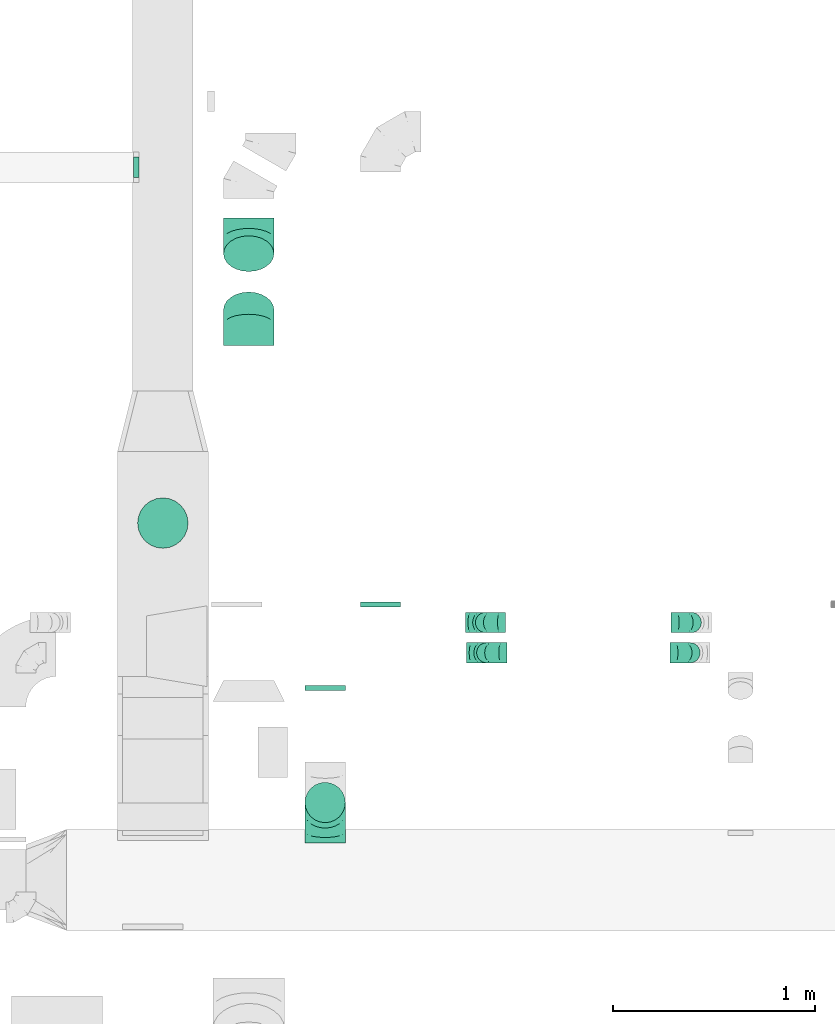
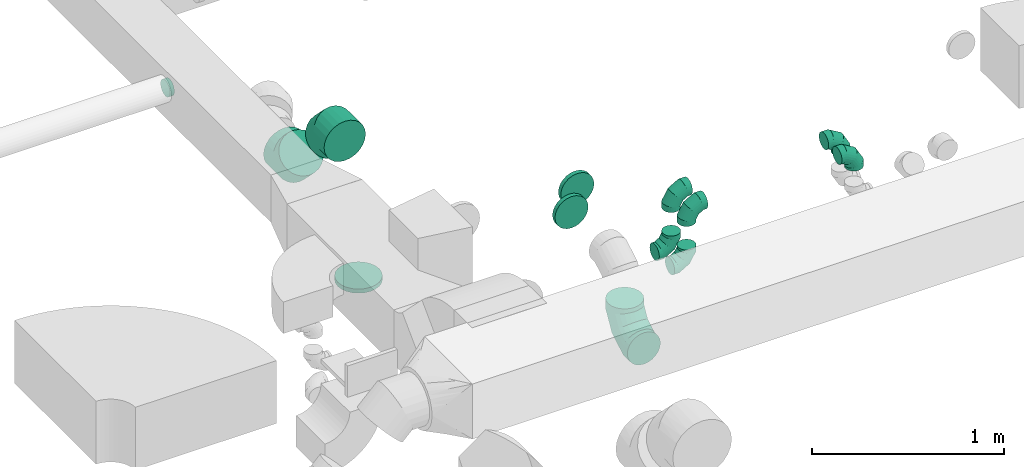
# One storey, part 30 of 62: 13 flow fittings.
"""IFC2X3 building model written with IfcOpenShell, lengths in millimetres."""

from ifc_helpers import new_model, entity, si_unit, converted_unit, derived_unit, direction, frame, origin, place, context, subcontext, project, spatial, faceted_brep, source, transform, mapped, material, type_object, type_shapes, element, save


model = new_model("IFC2X3")

# Units and contexts
model_context = context("Model", 3, precision=0.01, world=origin(), true_north=direction((6.12303176911189e-17, 1.0)))
body_context = subcontext(model_context, "Body", "Model", "MODEL_VIEW")
ifc_project = project(units=[si_unit("LENGTHUNIT", "METRE", prefix="MILLI"), si_unit("AREAUNIT", "SQUARE_METRE"), si_unit("VOLUMEUNIT", "CUBIC_METRE"), converted_unit("PLANEANGLEUNIT", "DEGREE", entity("IfcRatioMeasure", 0.0174532925199433), si_unit("PLANEANGLEUNIT", "RADIAN"), dimensions=[0, 0, 0, 0, 0, 0, 0]), si_unit("MASSUNIT", "GRAM", prefix="KILO"), derived_unit("MASSDENSITYUNIT", [(si_unit("MASSUNIT", "GRAM", prefix="KILO"), 1), (si_unit("LENGTHUNIT", "METRE"), -3)]), derived_unit("MOMENTOFINERTIAUNIT", [(si_unit("LENGTHUNIT", "METRE"), 4)]), si_unit("TIMEUNIT", "SECOND"), si_unit("FREQUENCYUNIT", "HERTZ"), si_unit("THERMODYNAMICTEMPERATUREUNIT", "DEGREE_CELSIUS"), derived_unit("THERMALTRANSMITTANCEUNIT", [(si_unit("MASSUNIT", "GRAM", prefix="KILO"), 1), (si_unit("THERMODYNAMICTEMPERATUREUNIT", "KELVIN"), -1), (si_unit("TIMEUNIT", "SECOND"), -3)]), derived_unit("VOLUMETRICFLOWRATEUNIT", [(si_unit("LENGTHUNIT", "METRE"), 3), (si_unit("TIMEUNIT", "SECOND"), -1)]), derived_unit("MASSFLOWRATEUNIT", [(si_unit("MASSUNIT", "GRAM", prefix="KILO"), 1), (si_unit("TIMEUNIT", "SECOND"), -1)]), derived_unit("ROTATIONALFREQUENCYUNIT", [(si_unit("TIMEUNIT", "SECOND"), -1)]), si_unit("ELECTRICCURRENTUNIT", "AMPERE"), si_unit("ELECTRICVOLTAGEUNIT", "VOLT"), si_unit("POWERUNIT", "WATT"), si_unit("FORCEUNIT", "NEWTON", prefix="KILO"), si_unit("ILLUMINANCEUNIT", "LUX"), si_unit("LUMINOUSFLUXUNIT", "LUMEN"), si_unit("LUMINOUSINTENSITYUNIT", "CANDELA"), derived_unit("USERDEFINED", [(si_unit("MASSUNIT", "GRAM", prefix="KILO"), -1), (si_unit("LENGTHUNIT", "METRE"), -2), (si_unit("TIMEUNIT", "SECOND"), 3), (si_unit("LUMINOUSFLUXUNIT", "LUMEN"), 1)]), derived_unit("LINEARVELOCITYUNIT", [(si_unit("LENGTHUNIT", "METRE"), 1), (si_unit("TIMEUNIT", "SECOND"), -1)]), si_unit("PRESSUREUNIT", "PASCAL"), derived_unit("USERDEFINED", [(si_unit("LENGTHUNIT", "METRE"), -2), (si_unit("MASSUNIT", "GRAM", prefix="KILO"), 1), (si_unit("TIMEUNIT", "SECOND"), -2)]), derived_unit("LINEARFORCEUNIT", [(si_unit("MASSUNIT", "GRAM", prefix="KILO"), 1), (si_unit("LENGTHUNIT", "METRE"), 1), (si_unit("TIMEUNIT", "SECOND"), -2), (si_unit("LENGTHUNIT", "METRE"), -1)]), derived_unit("PLANARFORCEUNIT", [(si_unit("MASSUNIT", "GRAM", prefix="KILO"), 1), (si_unit("LENGTHUNIT", "METRE"), 1), (si_unit("TIMEUNIT", "SECOND"), -2), (si_unit("LENGTHUNIT", "METRE"), -2)])], contexts=[model_context])

# Site, building, storey
site_placement = place(None, origin())
site = spatial("IfcSite", under=ifc_project, at=site_placement, CompositionType="ELEMENT")
building_placement = place(site_placement, origin())
building = spatial("IfcBuilding", under=site, at=building_placement, CompositionType="ELEMENT")
storey_placement = place(building_placement, frame((0.0, 0.0, 24000.0)))
storey = spatial("IfcBuildingStorey", under=building, at=storey_placement, CompositionType="ELEMENT", Elevation=24000.0)

# Flow fittings
ifc_material = material()
duct_fitting_type_1 = type_object("IfcDuctFittingType", PredefinedType="NOTDEFINED", material=ifc_material)
shared_shape_1 = source(origin(), body_context, "Body", "Brep", [
    faceted_brep([(-100.0, 0.0, -50.0), (-100.0, -12.94, -48.3), (-100.0, -25.0, -43.3), (-100.0, -35.36, -35.36), (-100.0, -43.3, -25.0), (-100.0, -48.3, -12.94), (-100.0, -50.0, 0.0), (-100.0, -48.3, 12.94), (-100.0, -43.3, 25.0), (-100.0, -35.36, 35.36), (-100.0, -25.0, 43.3), (-100.0, -12.94, 48.3), (-100.0, 0.0, 50.0), (-100.0, 12.94, 48.3), (-100.0, 25.0, 43.3), (-100.0, 35.36, 35.36), (-100.0, 43.3, 25.0), (-100.0, 48.3, 12.94), (-100.0, 50.0, 0.0), (-100.0, 48.3, -12.94), (-100.0, 43.3, -25.0), (-100.0, 35.36, -35.36), (-100.0, 25.0, -43.3), (-100.0, 12.94, -48.3), (-76.67, 12.94, 48.3), (-79.9, 25.0, 43.3), (-73.21, 0.0, 50.0), (-82.68, 35.36, 35.36), (-86.15, 48.3, 12.94), (-86.6, 50.0, 0.0), (-84.81, 43.3, 25.0), (-84.81, 43.3, -25.0), (-82.68, 35.36, -35.36), (-86.15, 48.3, -12.94), (-76.67, 12.94, -48.3), (-73.21, 0.0, -50.0), (-79.9, 25.0, -43.3), (-69.74, -12.94, -48.3), (-66.51, -25.0, -43.3), (-63.73, -35.36, -35.36), (-61.6, -43.3, -25.0), (-60.26, -48.3, -12.94), (-59.81, -50.0, 0.0), (-60.26, -48.3, 12.94), (-61.6, -43.3, 25.0), (-63.73, -35.36, 35.36), (-66.51, -25.0, 43.3), (-69.74, -12.94, 48.3), (-36.27, 36.27, 48.3), (-45.1, 45.1, 43.3), (-26.79, 26.79, 50.0), (-52.68, 52.68, 35.36), (-58.49, 58.49, 25.0), (-62.15, 62.15, 12.94), (-63.4, 63.4, 0.0), (-62.15, 62.15, -12.94), (-58.49, 58.49, -25.0), (-52.68, 52.68, -35.36), (-36.27, 36.27, -48.3), (-26.79, 26.79, -50.0), (-45.1, 45.1, -43.3), (-17.32, 17.32, -48.3), (-8.49, 8.49, -43.3), (-0.91, 0.91, -35.36), (4.9, -4.9, -25.0), (8.56, -8.56, -12.94), (9.81, -9.81, 0.0), (8.56, -8.56, 12.94), (4.9, -4.9, 25.0), (-0.91, 0.91, 35.36), (-8.49, 8.49, 43.3), (-17.32, 17.32, 48.3), (-12.94, 76.67, 48.3), (-25.0, 79.9, 43.3), (0.0, 73.21, 50.0), (-35.36, 82.68, 35.36), (-43.3, 84.81, 25.0), (-48.3, 86.15, 12.94), (-50.0, 86.6, 0.0), (-48.3, 86.15, -12.94), (-43.3, 84.81, -25.0), (-35.36, 82.68, -35.36), (-12.94, 76.67, -48.3), (0.0, 73.21, -50.0), (-25.0, 79.9, -43.3), (12.94, 69.74, -48.3), (25.0, 66.51, -43.3), (35.36, 63.73, -35.36), (43.3, 61.6, -25.0), (48.3, 60.26, -12.94), (50.0, 59.81, 0.0), (48.3, 60.26, 12.94), (43.3, 61.6, 25.0), (35.36, 63.73, 35.36), (25.0, 66.51, 43.3), (12.94, 69.74, 48.3), (-12.94, 100.0, -48.3), (-25.0, 100.0, -43.3), (-35.36, 100.0, -35.36), (-43.3, 100.0, -25.0), (-48.3, 100.0, -12.94), (-50.0, 100.0, 0.0), (-48.3, 100.0, 12.94), (-43.3, 100.0, 25.0), (-35.36, 100.0, 35.36), (-25.0, 100.0, 43.3), (-12.94, 100.0, 48.3), (0.0, 100.0, 50.0), (12.94, 100.0, 48.3), (25.0, 100.0, 43.3), (35.36, 100.0, 35.36), (43.3, 100.0, 25.0), (48.3, 100.0, 12.94), (50.0, 100.0, 0.0), (48.3, 100.0, -12.94), (43.3, 100.0, -25.0), (35.36, 100.0, -35.36), (25.0, 100.0, -43.3), (12.94, 100.0, -48.3), (0.0, 100.0, -50.0)], [[[0, 1, 2, 3, 4, 5, 6, 7, 8, 9, 10, 11, 12, 13, 14, 15, 16, 17, 18, 19, 20, 21, 22, 23]], [[24, 25, 14, 13]], [[26, 24, 13, 12]], [[14, 25, 27, 15]], [[28, 29, 18, 17]], [[30, 28, 17, 16]], [[15, 27, 30, 16]], [[20, 31, 32, 21]], [[33, 31, 20, 19]], [[18, 29, 33, 19]], [[34, 35, 0, 23]], [[36, 34, 23, 22]], [[32, 36, 22, 21]], [[2, 1, 37, 38]], [[3, 2, 38, 39]], [[0, 35, 37, 1]], [[5, 4, 40, 41]], [[6, 5, 41, 42]], [[3, 39, 40, 4]], [[6, 42, 43, 7]], [[7, 43, 44, 8]], [[8, 44, 45, 9]], [[10, 46, 47, 11]], [[11, 47, 26, 12]], [[10, 9, 45, 46]], [[48, 49, 25, 24]], [[50, 48, 24, 26]], [[27, 25, 49, 51]], [[52, 53, 28, 30]], [[51, 52, 30, 27]], [[29, 28, 53, 54]], [[55, 56, 31, 33]], [[54, 55, 33, 29]], [[57, 32, 31, 56]], [[58, 59, 35, 34]], [[60, 58, 34, 36]], [[57, 60, 36, 32]], [[37, 35, 59, 61]], [[38, 37, 61, 62]], [[39, 38, 62, 63]], [[41, 40, 64, 65]], [[42, 41, 65, 66]], [[63, 64, 40, 39]], [[43, 42, 66, 67]], [[44, 43, 67, 68]], [[68, 69, 45, 44]], [[46, 45, 69, 70]], [[47, 46, 70, 71]], [[26, 47, 71, 50]], [[72, 73, 49, 48]], [[74, 72, 48, 50]], [[51, 49, 73, 75]], [[76, 77, 53, 52]], [[75, 76, 52, 51]], [[54, 53, 77, 78]], [[79, 80, 56, 55]], [[78, 79, 55, 54]], [[81, 57, 56, 80]], [[82, 83, 59, 58]], [[84, 82, 58, 60]], [[81, 84, 60, 57]], [[61, 59, 83, 85]], [[62, 61, 85, 86]], [[63, 62, 86, 87]], [[65, 64, 88, 89]], [[66, 65, 89, 90]], [[87, 88, 64, 63]], [[67, 66, 90, 91]], [[68, 67, 91, 92]], [[92, 93, 69, 68]], [[70, 69, 93, 94]], [[71, 70, 94, 95]], [[50, 71, 95, 74]], [[96, 97, 98, 99, 100, 101, 102, 103, 104, 105, 106, 107, 108, 109, 110, 111, 112, 113, 114, 115, 116, 117, 118, 119]], [[72, 74, 107, 106]], [[73, 72, 106, 105]], [[75, 73, 105, 104]], [[77, 76, 103, 102]], [[78, 77, 102, 101]], [[75, 104, 103, 76]], [[78, 101, 100, 79]], [[79, 100, 99, 80]], [[80, 99, 98, 81]], [[96, 119, 83, 82]], [[97, 96, 82, 84]], [[84, 81, 98, 97]], [[83, 119, 118, 85]], [[85, 118, 117, 86]], [[86, 117, 116, 87]], [[88, 115, 114, 89]], [[89, 114, 113, 90]], [[87, 116, 115, 88]], [[91, 90, 113, 112]], [[92, 91, 112, 111]], [[93, 92, 111, 110]], [[95, 94, 109, 108]], [[74, 95, 108, 107]], [[110, 109, 94, 93]]]),
])
type_shapes(duct_fitting_type_1, [shared_shape_1])
for number, where, z_axis, x_axis in (
    (1, (42712.73, 10199.94, 3300.0), (0.0, -1.0, 0.0), (0.0, 0.0, 1.0)),
    (2, (41693.23, 10199.94, 3300.0), (0.0, 1.0, 0.0), (0.0, 0.0, 1.0)),
    (3, (42706.67, 10049.93, 3300.0), (0.0, 1.0, 0.0), (1.0, 0.0, 0.0)),
    (4, (41699.27, 10049.93, 3300.0), (0.0, -1.0, 0.0), (-1.0, 0.0, 0.0)),
    (5, (41699.27, 10049.93, 2950.0), (0.0, 1.0, 0.0), (0.0, 0.0, -1.0)),
    (6, (41693.23, 10199.94, 2950.0), (0.0, 1.0, 0.0), (0.0, 0.0, -1.0)),
):
    element("IfcFlowFitting", number, at=place(storey_placement, frame(where, z_axis=z_axis, x_axis=x_axis)), inside=storey, type_object=duct_fitting_type_1, material=ifc_material, context=body_context, shape_type="MappedRepresentation", body=[
        mapped(shared_shape_1, transform((0.0, 0.0, 0.0), scale=1.0)),
    ])
duct_fitting_type_2 = type_object("IfcDuctFittingType", PredefinedType="NOTDEFINED", material=ifc_material)
shared_shape_2 = source(origin(), body_context, "Body", "Brep", [
    faceted_brep([(20.0, 32.35, -120.74), (20.0, 62.5, -108.25), (20.0, 88.39, -88.39), (20.0, 108.25, -62.5), (20.0, 120.74, -32.35), (20.0, 125.0, 0.0), (20.0, 120.74, 32.35), (20.0, 108.25, 62.5), (20.0, 88.39, 88.39), (20.0, 62.5, 108.25), (20.0, 32.35, 120.74), (20.0, 0.0, 125.0), (20.0, -32.35, 120.74), (20.0, -62.5, 108.25), (20.0, -88.39, 88.39), (20.0, -108.25, 62.5), (20.0, -120.74, 32.35), (20.0, -125.0, 0.0), (20.0, -120.74, -32.35), (20.0, -108.25, -62.5), (20.0, -88.39, -88.39), (20.0, -62.5, -108.25), (20.0, -32.35, -120.74), (20.0, 0.0, -125.0), (0.0, 0.0, 125.0), (0.0, 32.35, 120.74), (-6.1, 32.35, 120.74), (-6.1, 0.0, 125.0), (0.0, 62.5, 108.25), (-6.1, 62.5, 108.25), (0.0, 88.39, 88.39), (-6.1, 88.39, 88.39), (0.0, 108.25, 62.5), (0.0, 120.74, 32.35), (-6.1, 120.74, 32.35), (-6.1, 108.25, 62.5), (0.0, 125.0, 0.0), (-6.1, 125.0, 0.0), (0.0, 120.74, -32.35), (-6.1, 120.74, -32.35), (0.0, 108.25, -62.5), (-6.1, 108.25, -62.5), (0.0, 88.39, -88.39), (-6.1, 88.39, -88.39), (0.0, 62.5, -108.25), (0.0, 32.35, -120.74), (-6.1, 32.35, -120.74), (-6.1, 62.5, -108.25), (0.0, 0.0, -125.0), (-6.1, 0.0, -125.0), (0.0, -32.35, -120.74), (-6.1, -32.35, -120.74), (0.0, -62.5, -108.25), (-6.1, -62.5, -108.25), (0.0, -88.39, -88.39), (-6.1, -88.39, -88.39), (0.0, -108.25, -62.5), (0.0, -120.74, -32.35), (-6.1, -120.74, -32.35), (-6.1, -108.25, -62.5), (0.0, -125.0, 0.0), (-6.1, -125.0, 0.0), (0.0, -120.74, 32.35), (-6.1, -120.74, 32.35), (0.0, -108.25, 62.5), (-6.1, -108.25, 62.5), (0.0, -88.39, 88.39), (-6.1, -88.39, 88.39), (0.0, -62.5, 108.25), (0.0, -32.35, 120.74), (-6.1, -32.35, 120.74), (-6.1, -62.5, 108.25)], [[[0, 1, 2, 3, 4, 5, 6, 7, 8, 9, 10, 11, 12, 13, 14, 15, 16, 17, 18, 19, 20, 21, 22, 23]], [[24, 11, 10, 25, 26, 27]], [[25, 10, 9, 28, 29, 26]], [[28, 9, 8, 30, 31, 29]], [[32, 7, 6, 33, 34, 35]], [[33, 6, 5, 36, 37, 34]], [[30, 8, 7, 32, 35, 31]], [[36, 5, 4, 38, 39, 37]], [[38, 4, 3, 40, 41, 39]], [[40, 3, 2, 42, 43, 41]], [[44, 1, 0, 45, 46, 47]], [[45, 0, 23, 48, 49, 46]], [[42, 2, 1, 44, 47, 43]], [[48, 23, 22, 50, 51, 49]], [[50, 22, 21, 52, 53, 51]], [[52, 21, 20, 54, 55, 53]], [[56, 19, 18, 57, 58, 59]], [[57, 18, 17, 60, 61, 58]], [[54, 20, 19, 56, 59, 55]], [[60, 17, 16, 62, 63, 61]], [[62, 16, 15, 64, 65, 63]], [[64, 15, 14, 66, 67, 65]], [[68, 13, 12, 69, 70, 71]], [[69, 12, 11, 24, 27, 70]], [[66, 14, 13, 68, 71, 67]], [[49, 51, 53, 55, 59, 58, 61, 63, 65, 67, 71, 70, 27, 26, 29, 31, 35, 34, 37, 39, 41, 43, 47, 46]]]),
])
type_shapes(duct_fitting_type_2, [shared_shape_2])
flow_fitting_1_placement = place(storey_placement, frame((40095.11, 10692.43, 3020.0), z_axis=(0.0, -1.0, 0.0), x_axis=(0.0, 0.0, -1.0)))
element("IfcFlowFitting", 7, at=flow_fitting_1_placement, inside=storey, type_object=duct_fitting_type_2, material=ifc_material, context=body_context, shape_type="MappedRepresentation", body=[
    mapped(shared_shape_2, transform((0.0, 0.0, 0.0), scale=1.0)),
])
duct_fitting_type_3 = type_object("IfcDuctFittingType", PredefinedType="NOTDEFINED", material=ifc_material)
shared_shape_3 = source(origin(), body_context, "Body", "Brep", [
    faceted_brep([(-200.0, 0.0, -100.0), (-200.0, -25.88, -96.59), (-200.0, -50.0, -86.6), (-200.0, -70.71, -70.71), (-200.0, -86.6, -50.0), (-200.0, -96.59, -25.88), (-200.0, -100.0, 0.0), (-200.0, -96.59, 25.88), (-200.0, -86.6, 50.0), (-200.0, -70.71, 70.71), (-200.0, -50.0, 86.6), (-200.0, -25.88, 96.59), (-200.0, 0.0, 100.0), (-200.0, 25.88, 96.59), (-200.0, 50.0, 86.6), (-200.0, 70.71, 70.71), (-200.0, 86.6, 50.0), (-200.0, 96.59, 25.88), (-200.0, 100.0, 0.0), (-200.0, 96.59, -25.88), (-200.0, 86.6, -50.0), (-200.0, 70.71, -70.71), (-200.0, 50.0, -86.6), (-200.0, 25.88, -96.59), (-153.35, 25.88, 96.59), (-159.81, 50.0, 86.6), (-146.41, 0.0, 100.0), (-165.36, 70.71, 70.71), (-172.29, 96.59, 25.88), (-173.21, 100.0, 0.0), (-169.62, 86.6, 50.0), (-169.62, 86.6, -50.0), (-165.36, 70.71, -70.71), (-172.29, 96.59, -25.88), (-153.35, 25.88, -96.59), (-146.41, 0.0, -100.0), (-159.81, 50.0, -86.6), (-139.48, -25.88, -96.59), (-133.01, -50.0, -86.6), (-127.46, -70.71, -70.71), (-123.21, -86.6, -50.0), (-120.53, -96.59, -25.88), (-119.62, -100.0, 0.0), (-120.53, -96.59, 25.88), (-123.21, -86.6, 50.0), (-127.46, -70.71, 70.71), (-133.01, -50.0, 86.6), (-139.48, -25.88, 96.59), (-72.54, 72.54, 96.59), (-90.19, 90.19, 86.6), (-53.59, 53.59, 100.0), (-105.35, 105.35, 70.71), (-116.99, 116.99, 50.0), (-124.3, 124.3, 25.88), (-126.79, 126.79, 0.0), (-124.3, 124.3, -25.88), (-116.99, 116.99, -50.0), (-105.35, 105.35, -70.71), (-72.54, 72.54, -96.59), (-53.59, 53.59, -100.0), (-90.19, 90.19, -86.6), (-34.64, 34.64, -96.59), (-16.99, 16.99, -86.6), (-1.83, 1.83, -70.71), (9.81, -9.81, -50.0), (17.12, -17.12, -25.88), (19.62, -19.62, 0.0), (17.12, -17.12, 25.88), (9.81, -9.81, 50.0), (-1.83, 1.83, 70.71), (-16.99, 16.99, 86.6), (-34.64, 34.64, 96.59), (-25.88, 153.35, 96.59), (-50.0, 159.81, 86.6), (0.0, 146.41, 100.0), (-70.71, 165.36, 70.71), (-86.6, 169.62, 50.0), (-96.59, 172.29, 25.88), (-100.0, 173.21, 0.0), (-96.59, 172.29, -25.88), (-86.6, 169.62, -50.0), (-70.71, 165.36, -70.71), (-25.88, 153.35, -96.59), (0.0, 146.41, -100.0), (-50.0, 159.81, -86.6), (25.88, 139.48, -96.59), (50.0, 133.01, -86.6), (70.71, 127.46, -70.71), (86.6, 123.21, -50.0), (96.59, 120.53, -25.88), (100.0, 119.62, 0.0), (96.59, 120.53, 25.88), (86.6, 123.21, 50.0), (70.71, 127.46, 70.71), (50.0, 133.01, 86.6), (25.88, 139.48, 96.59), (-25.88, 200.0, -96.59), (-50.0, 200.0, -86.6), (-70.71, 200.0, -70.71), (-86.6, 200.0, -50.0), (-96.59, 200.0, -25.88), (-100.0, 200.0, 0.0), (-96.59, 200.0, 25.88), (-86.6, 200.0, 50.0), (-70.71, 200.0, 70.71), (-50.0, 200.0, 86.6), (-25.88, 200.0, 96.59), (0.0, 200.0, 100.0), (25.88, 200.0, 96.59), (50.0, 200.0, 86.6), (70.71, 200.0, 70.71), (86.6, 200.0, 50.0), (96.59, 200.0, 25.88), (100.0, 200.0, 0.0), (96.59, 200.0, -25.88), (86.6, 200.0, -50.0), (70.71, 200.0, -70.71), (50.0, 200.0, -86.6), (25.88, 200.0, -96.59), (0.0, 200.0, -100.0)], [[[0, 1, 2, 3, 4, 5, 6, 7, 8, 9, 10, 11, 12, 13, 14, 15, 16, 17, 18, 19, 20, 21, 22, 23]], [[24, 25, 14, 13]], [[26, 24, 13, 12]], [[14, 25, 27, 15]], [[28, 29, 18, 17]], [[30, 28, 17, 16]], [[15, 27, 30, 16]], [[20, 31, 32, 21]], [[33, 31, 20, 19]], [[18, 29, 33, 19]], [[34, 35, 0, 23]], [[36, 34, 23, 22]], [[32, 36, 22, 21]], [[1, 0, 35, 37]], [[2, 1, 37, 38]], [[38, 39, 3, 2]], [[5, 4, 40, 41]], [[6, 5, 41, 42]], [[39, 40, 4, 3]], [[6, 42, 43, 7]], [[7, 43, 44, 8]], [[8, 44, 45, 9]], [[9, 45, 46, 10]], [[10, 46, 47, 11]], [[26, 12, 11, 47]], [[48, 49, 25, 24]], [[50, 48, 24, 26]], [[27, 25, 49, 51]], [[52, 53, 28, 30]], [[51, 52, 30, 27]], [[29, 28, 53, 54]], [[55, 56, 31, 33]], [[54, 55, 33, 29]], [[32, 31, 56, 57]], [[58, 59, 35, 34]], [[60, 58, 34, 36]], [[57, 60, 36, 32]], [[37, 35, 59, 61]], [[38, 37, 61, 62]], [[39, 38, 62, 63]], [[41, 40, 64, 65]], [[42, 41, 65, 66]], [[63, 64, 40, 39]], [[43, 42, 66, 67]], [[44, 43, 67, 68]], [[68, 69, 45, 44]], [[46, 45, 69, 70]], [[47, 46, 70, 71]], [[26, 47, 71, 50]], [[72, 73, 49, 48]], [[74, 72, 48, 50]], [[51, 49, 73, 75]], [[76, 77, 53, 52]], [[75, 76, 52, 51]], [[54, 53, 77, 78]], [[79, 80, 56, 55]], [[78, 79, 55, 54]], [[57, 56, 80, 81]], [[82, 83, 59, 58]], [[84, 82, 58, 60]], [[81, 84, 60, 57]], [[61, 59, 83, 85]], [[62, 61, 85, 86]], [[63, 62, 86, 87]], [[65, 64, 88, 89]], [[66, 65, 89, 90]], [[87, 88, 64, 63]], [[67, 66, 90, 91]], [[68, 67, 91, 92]], [[92, 93, 69, 68]], [[70, 69, 93, 94]], [[71, 70, 94, 95]], [[50, 71, 95, 74]], [[96, 97, 98, 99, 100, 101, 102, 103, 104, 105, 106, 107, 108, 109, 110, 111, 112, 113, 114, 115, 116, 117, 118, 119]], [[72, 74, 107, 106]], [[73, 72, 106, 105]], [[75, 73, 105, 104]], [[102, 101, 78, 77]], [[103, 102, 77, 76]], [[75, 104, 103, 76]], [[78, 101, 100, 79]], [[79, 100, 99, 80]], [[80, 99, 98, 81]], [[84, 97, 96, 82]], [[82, 96, 119, 83]], [[84, 81, 98, 97]], [[118, 117, 86, 85]], [[119, 118, 85, 83]], [[116, 87, 86, 117]], [[88, 115, 114, 89]], [[89, 114, 113, 90]], [[115, 88, 87, 116]], [[91, 90, 113, 112]], [[92, 91, 112, 111]], [[111, 110, 93, 92]], [[95, 94, 109, 108]], [[74, 95, 108, 107]], [[110, 109, 94, 93]]]),
])
type_shapes(duct_fitting_type_3, [shared_shape_3])
flow_fitting_2_placement = place(storey_placement, frame((40899.04, 9308.41, 3240.0), z_axis=(-1.0, 0.0, 0.0), x_axis=(0.0, 0.0, -1.0)))
element("IfcFlowFitting", 8, at=flow_fitting_2_placement, inside=storey, type_object=duct_fitting_type_3, material=ifc_material, context=body_context, shape_type="MappedRepresentation", body=[
    mapped(shared_shape_3, transform((0.0, 0.0, 0.0), scale=1.0)),
])
duct_fitting_type_4 = type_object("IfcDuctFittingType", PredefinedType="NOTDEFINED", material=ifc_material)
shared_shape_4 = source(origin(), body_context, "Body", "Brep", [
    faceted_brep([(20.0, 25.88, -96.59), (20.0, 50.0, -86.6), (20.0, 70.71, -70.71), (20.0, 86.6, -50.0), (20.0, 96.59, -25.88), (20.0, 100.0, 0.0), (20.0, 96.59, 25.88), (20.0, 86.6, 50.0), (20.0, 70.71, 70.71), (20.0, 50.0, 86.6), (20.0, 25.88, 96.59), (20.0, 0.0, 100.0), (20.0, -25.88, 96.59), (20.0, -50.0, 86.6), (20.0, -70.71, 70.71), (20.0, -86.6, 50.0), (20.0, -96.59, 25.88), (20.0, -100.0, 0.0), (20.0, -96.59, -25.88), (20.0, -86.6, -50.0), (20.0, -70.71, -70.71), (20.0, -50.0, -86.6), (20.0, -25.88, -96.59), (20.0, 0.0, -100.0), (0.0, 0.0, 100.0), (0.0, 25.88, 96.59), (-6.1, 25.88, 96.59), (-6.1, 0.0, 100.0), (0.0, 50.0, 86.6), (-6.1, 50.0, 86.6), (0.0, 70.71, 70.71), (-6.1, 70.71, 70.71), (0.0, 86.6, 50.0), (0.0, 96.59, 25.88), (-6.1, 96.59, 25.88), (-6.1, 86.6, 50.0), (0.0, 100.0, 0.0), (-6.1, 100.0, 0.0), (0.0, 96.59, -25.88), (-6.1, 96.59, -25.88), (0.0, 86.6, -50.0), (-6.1, 86.6, -50.0), (0.0, 70.71, -70.71), (-6.1, 70.71, -70.71), (0.0, 50.0, -86.6), (0.0, 25.88, -96.59), (-6.1, 25.88, -96.59), (-6.1, 50.0, -86.6), (0.0, 0.0, -100.0), (-6.1, 0.0, -100.0), (0.0, -25.88, -96.59), (-6.1, -25.88, -96.59), (0.0, -50.0, -86.6), (-6.1, -50.0, -86.6), (0.0, -70.71, -70.71), (-6.1, -70.71, -70.71), (0.0, -86.6, -50.0), (0.0, -96.59, -25.88), (-6.1, -96.59, -25.88), (-6.1, -86.6, -50.0), (0.0, -100.0, 0.0), (-6.1, -100.0, 0.0), (0.0, -96.59, 25.88), (-6.1, -96.59, 25.88), (0.0, -86.6, 50.0), (-6.1, -86.6, 50.0), (0.0, -70.71, 70.71), (-6.1, -70.71, 70.71), (0.0, -50.0, 86.6), (0.0, -25.88, 96.59), (-6.1, -25.88, 96.59), (-6.1, -50.0, 86.6)], [[[0, 1, 2, 3, 4, 5, 6, 7, 8, 9, 10, 11, 12, 13, 14, 15, 16, 17, 18, 19, 20, 21, 22, 23]], [[24, 11, 10, 25, 26, 27]], [[25, 10, 9, 28, 29, 26]], [[28, 9, 8, 30, 31, 29]], [[32, 7, 6, 33, 34, 35]], [[33, 6, 5, 36, 37, 34]], [[30, 8, 7, 32, 35, 31]], [[36, 5, 4, 38, 39, 37]], [[38, 4, 3, 40, 41, 39]], [[40, 3, 2, 42, 43, 41]], [[44, 1, 0, 45, 46, 47]], [[45, 0, 23, 48, 49, 46]], [[42, 2, 1, 44, 47, 43]], [[48, 23, 22, 50, 51, 49]], [[50, 22, 21, 52, 53, 51]], [[52, 21, 20, 54, 55, 53]], [[56, 19, 18, 57, 58, 59]], [[57, 18, 17, 60, 61, 58]], [[54, 20, 19, 56, 59, 55]], [[60, 17, 16, 62, 63, 61]], [[62, 16, 15, 64, 65, 63]], [[64, 15, 14, 66, 67, 65]], [[68, 13, 12, 69, 70, 71]], [[69, 12, 11, 24, 27, 70]], [[66, 14, 13, 68, 71, 67]], [[49, 51, 53, 55, 59, 58, 61, 63, 65, 67, 71, 70, 27, 26, 29, 31, 35, 34, 37, 39, 41, 43, 47, 46]]]),
])
type_shapes(duct_fitting_type_4, [shared_shape_4])
flow_fitting_3_placement = place(storey_placement, frame((40899.04, 9882.41, 3650.0), z_axis=(0.0, 0.0, -1.0), x_axis=(0.0, -1.0, 0.0)))
element("IfcFlowFitting", 9, at=flow_fitting_3_placement, inside=storey, type_object=duct_fitting_type_4, material=ifc_material, context=body_context, shape_type="MappedRepresentation", body=[
    mapped(shared_shape_4, transform((0.0, 0.0, 0.0), scale=1.0)),
])
duct_fitting_type_5 = type_object("IfcDuctFittingType", PredefinedType="NOTDEFINED", material=ifc_material)
shared_shape_5 = source(origin(), body_context, "Body", "Brep", [
    faceted_brep([(20.0, 0.0, -50.0), (20.0, 12.94, -48.3), (20.0, 25.0, -43.3), (20.0, 35.36, -35.36), (20.0, 43.3, -25.0), (20.0, 48.3, -12.94), (20.0, 50.0, 0.0), (20.0, 48.3, 12.94), (20.0, 43.3, 25.0), (20.0, 35.36, 35.36), (20.0, 25.0, 43.3), (20.0, 12.94, 48.3), (20.0, 0.0, 50.0), (20.0, -12.94, 48.3), (20.0, -25.0, 43.3), (20.0, -35.36, 35.36), (20.0, -43.3, 25.0), (20.0, -48.3, 12.94), (20.0, -50.0, 0.0), (20.0, -48.3, -12.94), (20.0, -43.3, -25.0), (20.0, -35.36, -35.36), (20.0, -25.0, -43.3), (20.0, -12.94, -48.3), (0.0, 0.0, 50.0), (-6.1, 0.0, 50.0), (-6.1, -12.94, 48.3), (0.0, -12.94, 48.3), (-6.1, -25.0, 43.3), (0.0, -25.0, 43.3), (0.0, -35.36, 35.36), (-6.1, -35.36, 35.36), (0.0, -43.3, 25.0), (-6.1, -43.3, 25.0), (-6.1, -48.3, 12.94), (0.0, -48.3, 12.94), (-6.1, -50.0, 0.0), (0.0, -50.0, 0.0), (-6.1, -48.3, -12.94), (0.0, -48.3, -12.94), (-6.1, -43.3, -25.0), (0.0, -43.3, -25.0), (0.0, -35.36, -35.36), (-6.1, -35.36, -35.36), (0.0, -25.0, -43.3), (-6.1, -25.0, -43.3), (-6.1, -12.94, -48.3), (0.0, -12.94, -48.3), (-6.1, 0.0, -50.0), (0.0, 0.0, -50.0), (-6.1, 12.94, -48.3), (0.0, 12.94, -48.3), (-6.1, 25.0, -43.3), (0.0, 25.0, -43.3), (0.0, 35.36, -35.36), (-6.1, 35.36, -35.36), (0.0, 43.3, -25.0), (-6.1, 43.3, -25.0), (-6.1, 48.3, -12.94), (0.0, 48.3, -12.94), (-6.1, 50.0, 0.0), (0.0, 50.0, 0.0), (-6.1, 48.3, 12.94), (0.0, 48.3, 12.94), (-6.1, 43.3, 25.0), (0.0, 43.3, 25.0), (0.0, 35.36, 35.36), (-6.1, 35.36, 35.36), (0.0, 25.0, 43.3), (-6.1, 25.0, 43.3), (-6.1, 12.94, 48.3), (0.0, 12.94, 48.3)], [[[0, 1, 2, 3, 4, 5, 6, 7, 8, 9, 10, 11, 12, 13, 14, 15, 16, 17, 18, 19, 20, 21, 22, 23]], [[13, 12, 24, 25, 26, 27]], [[14, 13, 27, 26, 28, 29]], [[30, 15, 14, 29, 28, 31]], [[17, 16, 32, 33, 34, 35]], [[18, 17, 35, 34, 36, 37]], [[32, 16, 15, 30, 31, 33]], [[19, 18, 37, 36, 38, 39]], [[20, 19, 39, 38, 40, 41]], [[42, 21, 20, 41, 40, 43]], [[23, 22, 44, 45, 46, 47]], [[0, 23, 47, 46, 48, 49]], [[44, 22, 21, 42, 43, 45]], [[1, 0, 49, 48, 50, 51]], [[2, 1, 51, 50, 52, 53]], [[54, 3, 2, 53, 52, 55]], [[5, 4, 56, 57, 58, 59]], [[6, 5, 59, 58, 60, 61]], [[56, 4, 3, 54, 55, 57]], [[7, 6, 61, 60, 62, 63]], [[8, 7, 63, 62, 64, 65]], [[66, 9, 8, 65, 64, 67]], [[11, 10, 68, 69, 70, 71]], [[12, 11, 71, 70, 25, 24]], [[68, 10, 9, 66, 67, 69]], [[46, 45, 43, 40, 38, 36, 34, 33, 31, 28, 26, 25, 70, 69, 67, 64, 62, 60, 58, 57, 55, 52, 50, 48]]]),
])
type_shapes(duct_fitting_type_5, [shared_shape_5])
flow_fitting_4_placement = place(storey_placement, frame((39970.11, 12455.11, 3200.0), z_axis=(0.0, 0.0, -1.0), x_axis=(-1.0, 0.0, 0.0)))
element("IfcFlowFitting", 10, at=flow_fitting_4_placement, inside=storey, type_object=duct_fitting_type_5, material=ifc_material, context=body_context, shape_type="MappedRepresentation", body=[
    mapped(shared_shape_5, transform((0.0, 0.0, 0.0), scale=1.0)),
])
duct_fitting_type_6 = type_object("IfcDuctFittingType", PredefinedType="NOTDEFINED", material=ifc_material)
shared_shape_6 = source(origin(), body_context, "Body", "Brep", [
    faceted_brep([(20.0, 0.0, -100.0), (20.0, 25.88, -96.59), (20.0, 50.0, -86.6), (20.0, 70.71, -70.71), (20.0, 86.6, -50.0), (20.0, 96.59, -25.88), (20.0, 100.0, 0.0), (20.0, 96.59, 25.88), (20.0, 86.6, 50.0), (20.0, 70.71, 70.71), (20.0, 50.0, 86.6), (20.0, 25.88, 96.59), (20.0, 0.0, 100.0), (20.0, -25.88, 96.59), (20.0, -50.0, 86.6), (20.0, -70.71, 70.71), (20.0, -86.6, 50.0), (20.0, -96.59, 25.88), (20.0, -100.0, 0.0), (20.0, -96.59, -25.88), (20.0, -86.6, -50.0), (20.0, -70.71, -70.71), (20.0, -50.0, -86.6), (20.0, -25.88, -96.59), (0.0, 0.0, 100.0), (-6.1, 0.0, 100.0), (-6.1, -25.88, 96.59), (0.0, -25.88, 96.59), (-6.1, -50.0, 86.6), (0.0, -50.0, 86.6), (0.0, -70.71, 70.71), (-6.1, -70.71, 70.71), (0.0, -86.6, 50.0), (-6.1, -86.6, 50.0), (-6.1, -96.59, 25.88), (0.0, -96.59, 25.88), (-6.1, -100.0, 0.0), (0.0, -100.0, 0.0), (-6.1, -96.59, -25.88), (0.0, -96.59, -25.88), (-6.1, -86.6, -50.0), (0.0, -86.6, -50.0), (0.0, -70.71, -70.71), (-6.1, -70.71, -70.71), (0.0, -50.0, -86.6), (-6.1, -50.0, -86.6), (-6.1, -25.88, -96.59), (0.0, -25.88, -96.59), (-6.1, 0.0, -100.0), (0.0, 0.0, -100.0), (-6.1, 25.88, -96.59), (0.0, 25.88, -96.59), (-6.1, 50.0, -86.6), (0.0, 50.0, -86.6), (0.0, 70.71, -70.71), (-6.1, 70.71, -70.71), (0.0, 86.6, -50.0), (-6.1, 86.6, -50.0), (-6.1, 96.59, -25.88), (0.0, 96.59, -25.88), (-6.1, 100.0, 0.0), (0.0, 100.0, 0.0), (-6.1, 96.59, 25.88), (0.0, 96.59, 25.88), (-6.1, 86.6, 50.0), (0.0, 86.6, 50.0), (0.0, 70.71, 70.71), (-6.1, 70.71, 70.71), (0.0, 50.0, 86.6), (-6.1, 50.0, 86.6), (-6.1, 25.88, 96.59), (0.0, 25.88, 96.59)], [[[0, 1, 2, 3, 4, 5, 6, 7, 8, 9, 10, 11, 12, 13, 14, 15, 16, 17, 18, 19, 20, 21, 22, 23]], [[13, 12, 24, 25, 26, 27]], [[14, 13, 27, 26, 28, 29]], [[30, 15, 14, 29, 28, 31]], [[17, 16, 32, 33, 34, 35]], [[18, 17, 35, 34, 36, 37]], [[32, 16, 15, 30, 31, 33]], [[19, 18, 37, 36, 38, 39]], [[20, 19, 39, 38, 40, 41]], [[42, 21, 20, 41, 40, 43]], [[23, 22, 44, 45, 46, 47]], [[0, 23, 47, 46, 48, 49]], [[44, 22, 21, 42, 43, 45]], [[1, 0, 49, 48, 50, 51]], [[2, 1, 51, 50, 52, 53]], [[54, 3, 2, 53, 52, 55]], [[5, 4, 56, 57, 58, 59]], [[6, 5, 59, 58, 60, 61]], [[56, 4, 3, 54, 55, 57]], [[7, 6, 61, 60, 62, 63]], [[8, 7, 63, 62, 64, 65]], [[66, 9, 8, 65, 64, 67]], [[11, 10, 68, 69, 70, 71]], [[12, 11, 71, 70, 25, 24]], [[68, 10, 9, 66, 67, 69]], [[46, 45, 43, 40, 38, 36, 34, 33, 31, 28, 26, 25, 70, 69, 67, 64, 62, 60, 58, 57, 55, 52, 50, 48]]]),
])
type_shapes(duct_fitting_type_6, [shared_shape_6])
flow_fitting_5_placement = place(storey_placement, frame((41173.1, 10282.41, 3450.0), z_axis=(0.0, 0.0, -1.0), x_axis=(0.0, 1.0, 0.0)))
element("IfcFlowFitting", 11, at=flow_fitting_5_placement, inside=storey, type_object=duct_fitting_type_6, material=ifc_material, context=body_context, shape_type="MappedRepresentation", body=[
    mapped(shared_shape_6, transform((0.0, 0.0, 0.0), scale=1.0)),
])
duct_fitting_type_7 = type_object("IfcDuctFittingType", PredefinedType="NOTDEFINED", material=ifc_material)
shared_shape_7 = source(origin(), body_context, "Body", "Brep", [
    faceted_brep([(-103.55, 0.0, -125.0), (-103.55, -32.35, -120.74), (-103.55, -62.5, -108.25), (-103.55, -88.39, -88.39), (-103.55, -108.25, -62.5), (-103.55, -120.74, -32.35), (-103.55, -125.0, 0.0), (-103.55, -120.74, 32.35), (-103.55, -108.25, 62.5), (-103.55, -88.39, 88.39), (-103.55, -62.5, 108.25), (-103.55, -32.35, 120.74), (-103.55, 0.0, 125.0), (-103.55, 32.35, 120.74), (-103.55, 62.5, 108.25), (-103.55, 88.39, 88.39), (-103.55, 108.25, 62.5), (-103.55, 120.74, 32.35), (-103.55, 125.0, 0.0), (-103.55, 120.74, -32.35), (-103.55, 108.25, -62.5), (-103.55, 88.39, -88.39), (-103.55, 62.5, -108.25), (-103.55, 32.35, -120.74), (-13.4, 32.35, 120.74), (-25.89, 62.5, 108.25), (0.0, 0.0, 125.0), (-36.61, 88.39, 88.39), (-44.84, 108.25, 62.5), (-50.01, 120.74, 32.35), (-51.78, 125.0, 0.0), (-50.01, 120.74, -32.35), (-44.84, 108.25, -62.5), (-36.61, 88.39, -88.39), (-13.4, 32.35, -120.74), (0.0, 0.0, -125.0), (-25.89, 62.5, -108.25), (13.4, -32.35, -120.74), (25.89, -62.5, -108.25), (36.61, -88.39, -88.39), (44.84, -108.25, -62.5), (50.01, -120.74, -32.35), (51.78, -125.0, 0.0), (50.01, -120.74, 32.35), (44.84, -108.25, 62.5), (36.61, -88.39, 88.39), (25.89, -62.5, 108.25), (13.4, -32.35, 120.74), (73.22, 73.22, 125.0), (50.35, 96.1, 120.74), (29.03, 117.42, 108.25), (10.72, 135.72, 88.39), (-3.32, 149.77, 62.5), (-12.15, 158.6, 32.35), (-15.17, 161.61, 0.0), (-12.15, 158.6, -32.35), (-3.32, 149.77, -62.5), (10.72, 135.72, -88.39), (29.03, 117.42, -108.25), (50.35, 96.1, -120.74), (73.22, 73.22, -125.0), (96.1, 50.35, -120.74), (117.42, 29.03, -108.25), (135.72, 10.72, -88.39), (149.77, -3.32, -62.5), (158.6, -12.15, -32.35), (161.61, -15.17, 0.0), (158.6, -12.15, 32.35), (149.77, -3.32, 62.5), (135.72, 10.72, 88.39), (117.42, 29.03, 108.25), (96.1, 50.35, 120.74)], [[[0, 1, 2, 3, 4, 5, 6, 7, 8, 9, 10, 11, 12, 13, 14, 15, 16, 17, 18, 19, 20, 21, 22, 23]], [[24, 25, 14, 13]], [[26, 24, 13, 12]], [[14, 25, 27, 15]], [[28, 29, 17, 16]], [[28, 16, 15, 27]], [[30, 18, 17, 29]], [[31, 32, 20, 19]], [[30, 31, 19, 18]], [[32, 33, 21, 20]], [[34, 35, 0, 23]], [[36, 34, 23, 22]], [[33, 36, 22, 21]], [[1, 0, 35, 37]], [[2, 1, 37, 38]], [[38, 39, 3, 2]], [[5, 4, 40, 41]], [[6, 5, 41, 42]], [[39, 40, 4, 3]], [[6, 42, 43, 7]], [[7, 43, 44, 8]], [[8, 44, 45, 9]], [[9, 45, 46, 10]], [[10, 46, 47, 11]], [[26, 12, 11, 47]], [[24, 26, 48, 49]], [[25, 24, 49, 50]], [[27, 25, 50, 51]], [[29, 28, 52, 53]], [[30, 29, 53, 54]], [[51, 52, 28, 27]], [[30, 54, 55, 31]], [[31, 55, 56, 32]], [[57, 33, 32, 56]], [[36, 58, 59, 34]], [[34, 59, 60, 35]], [[58, 36, 33, 57]], [[35, 60, 61, 37]], [[37, 61, 62, 38]], [[63, 39, 38, 62]], [[40, 64, 65, 41]], [[41, 65, 66, 42]], [[64, 40, 39, 63]], [[43, 42, 66, 67]], [[44, 43, 67, 68]], [[68, 69, 45, 44]], [[47, 46, 70, 71]], [[26, 47, 71, 48]], [[69, 70, 46, 45]], [[59, 58, 57, 56, 55, 54, 53, 52, 51, 50, 49, 48, 71, 70, 69, 68, 67, 66, 65, 64, 63, 62, 61, 60]]]),
])
type_shapes(duct_fitting_type_7, [shared_shape_7])
for number, where, z_axis, x_axis in (
    (12, (40520.63, 11675.19, 3200.0), (-1.0, 0.0, 0.0), (0.0, 1.0, 0.0)),
    (13, (40520.63, 12100.19, 2775.0), (1.0, 0.0, 0.0), (0.0, 0.70710678118653, -0.707106781186565)),
):
    element("IfcFlowFitting", number, at=place(storey_placement, frame(where, z_axis=z_axis, x_axis=x_axis)), inside=storey, type_object=duct_fitting_type_7, material=ifc_material, context=body_context, shape_type="MappedRepresentation", body=[
        mapped(shared_shape_7, transform((0.0, 0.0, 0.0), scale=1.0)),
    ])

save(model, "model.ifc")
